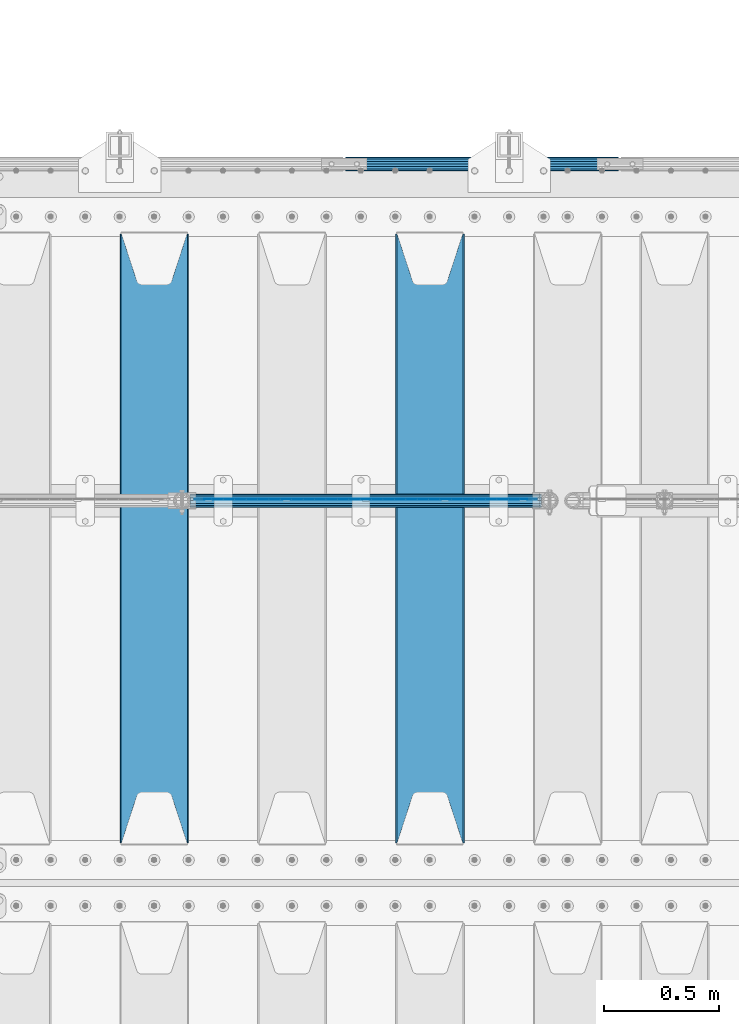
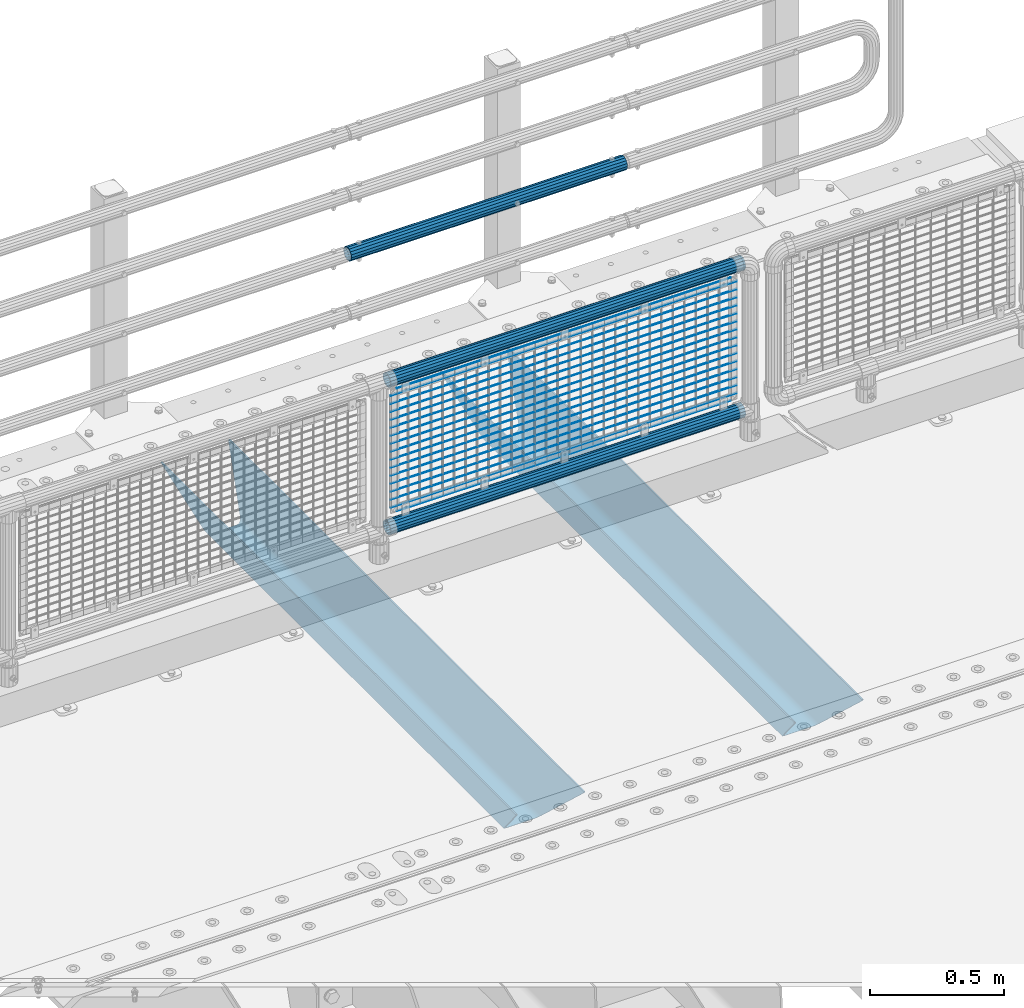
# One storey, part 129 of 247: 22 beams.
"""IFC2X3 building model written with IfcOpenShell, lengths in millimetres."""

from ifc_helpers import new_model, si_unit, frame, origin_with_axes, place, context, subcontext, project, spatial, faceted_brep, material, type_object, element, save


model = new_model("IFC2X3")

# Units and contexts
model_context = context("Model", 3, precision=1e-05, world=origin_with_axes())
body_context = subcontext(model_context, "Body", "Model", "MODEL_VIEW")
ifc_project = project(units=[si_unit("LENGTHUNIT", "METRE", prefix="MILLI"), si_unit("AREAUNIT", "SQUARE_METRE"), si_unit("VOLUMEUNIT", "CUBIC_METRE"), si_unit("MASSUNIT", "GRAM", prefix="KILO"), si_unit("TIMEUNIT", "SECOND"), si_unit("PLANEANGLEUNIT", "RADIAN"), si_unit("SOLIDANGLEUNIT", "STERADIAN"), si_unit("THERMODYNAMICTEMPERATUREUNIT", "DEGREE_CELSIUS"), si_unit("LUMINOUSINTENSITYUNIT", "LUMEN")], contexts=[model_context])

# Site, building, storey
site_placement = place(None, origin_with_axes())
site = spatial("IfcSite", under=ifc_project, at=site_placement, CompositionType="ELEMENT")
building_placement = place(site_placement, origin_with_axes())
building = spatial("IfcBuilding", under=site, at=building_placement, Name="Standard", CompositionType="ELEMENT")
storey_placement = place(building_placement, origin_with_axes())
storey = spatial("IfcBuildingStorey", under=building, at=storey_placement, Name="Undefined", CompositionType="ELEMENT", Elevation=0.0)

# Beams
ifc_material_1 = material(Name="STEEL/S355N")
beam_type_1 = type_object("IfcBeamType", PredefinedType="NOTDEFINED")
beam_1_placement = place(storey_placement, frame((14500.0, 6175.0, -115.0), z_axis=(0.0, 0.0, 1.0), x_axis=(0.0, 1.0, 0.0)))
element("IfcBeam", 1, at=beam_1_placement, inside=storey, type_object=beam_type_1, material=ifc_material_1, context=body_context, shape_type="Brep", body=[
    faceted_brep([(0.0, 150.0, 115.0), (0.0, 143.689999999999, 115.0), (2650.00000000297, 143.689999999999, 115.0), (2650.00000000297, 150.0, 115.0), (2650.00000000297, 142.059565218402, 110.0000000031), (2650.00000000297, 148.369565218403, 110.0000000031), (2441.90079219208, -80.1103600731112, -98.0992078077845), (2437.7588105432, -77.5672621345584, -102.241189456673), (2434.06523489746, -74.4080125315522, -105.934765102404), (2430.91086095089, -70.710272125576, -109.089139048974), (2428.37322971128, -66.5649389910068, -111.626770288588), (2426.51472138054, -62.0739139532889, -113.485278619323), (2425.38102192091, -57.3475956567672, -114.618978078955), (2424.99999999987, -52.5021667386536, -115.0), (2424.99999999987, 52.5021667386536, -115.0), (2425.38102192091, 57.3475956567672, -114.618978078955), (2426.51472138054, 62.0739139532889, -113.485278619323), (2428.37322971128, 66.5649389910068, -111.626770288588), (2430.91086095089, 70.710272125576, -109.089139048974), (2434.06523489746, 74.4080125315522, -105.934765102404), (2437.7588105432, 77.5672621345584, -102.241189456673), (2441.90079219208, 80.1103600731112, -98.0992078077846), (2446.38936140511, 81.9747917625791, -93.6106385947584), (2448.24948500409, 76.2713538057251, -91.7505149957729), (2444.62967112262, 74.76777986261, -95.3703288772456), (2441.28936334126, 72.7168944282894, -98.710636658607), (2438.31067330438, 70.1691124903846, -101.689326695487), (2435.76682334747, 67.1870637758839, -104.233176652398), (2433.72034654133, 63.8440531834895, -106.279653458539), (2432.22154950041, 60.222258798236, -107.778450499454), (2431.30727574265, 56.4107117849089, -108.692724257221), (2430.99999999987, 52.5031078186876, -109.0), (2430.99999999987, -52.5031078186876, -109.0), (2431.30727574265, -56.4107117849089, -108.692724257221), (2432.22154950041, -60.222258798236, -107.778450499454), (2433.72034654133, -63.8440531834895, -106.279653458539), (2435.76682334747, -67.1870637758839, -104.233176652398), (2438.31067330438, -70.1691124903846, -101.689326695487), (2441.28936334126, -72.7168944282894, -98.7106366586071), (2444.62967112262, -74.76777986261, -95.3703288772457), (2448.24948500409, -76.2713538057251, -91.7505149957729), (2650.00000000297, -142.059565218402, 110.0000000031), (2650.00000000297, -148.369565218403, 110.0000000031), (2446.38936140511, -81.9747917625791, -93.6106385947584), (2650.00000000297, -143.689999999999, 115.0), (2650.00000000297, -150.0, 115.0), (0.0, -143.689999999999, 115.0), (0.0, -150.0, 115.0), (0.0, -148.369565218261, 110.000000002663), (203.610638597422, -81.9747917625791, -93.6106385947584), (208.099207810448, -80.1103600731112, -98.0992078077845), (212.241189459336, -77.5672621345584, -102.241189456673), (215.934765105068, -74.4080125315522, -105.934765102404), (219.089139051637, -70.710272125576, -109.089139048974), (221.626770291251, -66.5649389910068, -111.626770288588), (223.485278621985, -62.0739139532889, -113.485278619323), (224.618978081617, -57.3475956567672, -114.618978078955), (225.000000002663, -52.5021667386536, -115.0), (225.000000002663, 52.5021667386536, -115.0), (224.618978081617, 57.3475956567672, -114.618978078955), (223.485278621985, 62.0739139532889, -113.485278619323), (221.626770291251, 66.5649389910068, -111.626770288588), (219.089139051637, 70.710272125576, -109.089139048974), (215.934765105068, 74.4080125315522, -105.934765102404), (212.241189459336, 77.5672621345584, -102.241189456673), (208.099207810448, 80.1103600731112, -98.0992078077846), (203.610638597422, 81.9747917625791, -93.6106385947584), (0.0, 148.369565218261, 110.000000002663), (0.0, 142.05956521826, 110.000000002663), (201.750514998436, 76.2713538057251, -91.7505149957729), (205.370328879908, 74.76777986261, -95.3703288772456), (208.710636661271, 72.7168944282894, -98.710636658607), (211.68932669815, 70.1691124903846, -101.689326695487), (214.233176655061, 67.1870637758839, -104.233176652398), (216.279653461202, 63.8440531834895, -106.279653458539), (217.778450502117, 60.222258798236, -107.778450499454), (218.692724259885, 56.4107117849089, -108.692724257221), (219.000000002663, 52.5031078186876, -109.0), (219.000000002663, -52.5031078186876, -109.0), (218.692724259885, -56.4107117849089, -108.692724257221), (217.778450502117, -60.222258798236, -107.778450499454), (216.279653461202, -63.8440531834895, -106.279653458539), (214.233176655061, -67.1870637758839, -104.233176652398), (211.68932669815, -70.1691124903846, -101.689326695487), (208.710636661271, -72.7168944282894, -98.7106366586071), (205.370328879908, -74.76777986261, -95.3703288772457), (201.750514998436, -76.2713538057251, -91.7505149957729), (0.0, -142.05956521826, 110.000000002663)], [[[0, 1, 2, 3]], [[3, 2, 4, 5]], [[6, 7, 8, 9, 10, 11, 12, 13, 14, 15, 16, 17, 18, 19, 20, 21, 22, 5, 4, 23, 24, 25, 26, 27, 28, 29, 30, 31, 32, 33, 34, 35, 36, 37, 38, 39, 40, 41, 42, 43]], [[44, 45, 42, 41]], [[46, 47, 45, 44]], [[43, 42, 45, 47, 48, 49]], [[6, 43, 49, 50]], [[7, 6, 50, 51]], [[8, 7, 51, 52]], [[9, 8, 52, 53]], [[10, 9, 53, 54]], [[11, 10, 54, 55]], [[12, 11, 55, 56]], [[13, 12, 56, 57]], [[14, 13, 57, 58]], [[15, 14, 58, 59]], [[16, 15, 59, 60]], [[17, 16, 60, 61]], [[18, 17, 61, 62]], [[19, 18, 62, 63]], [[20, 19, 63, 64]], [[21, 20, 64, 65]], [[22, 21, 65, 66]], [[0, 3, 5, 22, 66, 67]], [[1, 0, 67, 68]], [[23, 4, 2, 1, 68, 69]], [[24, 23, 69, 70]], [[25, 24, 70, 71]], [[26, 25, 71, 72]], [[27, 26, 72, 73]], [[28, 27, 73, 74]], [[29, 28, 74, 75]], [[30, 29, 75, 76]], [[31, 30, 76, 77]], [[32, 31, 77, 78]], [[33, 32, 78, 79]], [[34, 33, 79, 80]], [[35, 34, 80, 81]], [[36, 35, 81, 82]], [[37, 36, 82, 83]], [[38, 37, 83, 84]], [[39, 38, 84, 85]], [[40, 39, 85, 86]], [[46, 44, 41, 40, 86, 87]], [[47, 46, 87, 48]], [[86, 85, 84, 83, 82, 81, 80, 79, 78, 77, 76, 75, 74, 73, 72, 71, 70, 69, 68, 67, 66, 65, 64, 63, 62, 61, 60, 59, 58, 57, 56, 55, 54, 53, 52, 51, 50, 49, 48, 87]]]),
])
beam_2_placement = place(storey_placement, frame((13300.0, 6175.0, -115.0), z_axis=(0.0, 0.0, 1.0), x_axis=(0.0, 1.0, 0.0)))
element("IfcBeam", 2, at=beam_2_placement, inside=storey, type_object=beam_type_1, material=ifc_material_1, context=body_context, shape_type="Brep", body=[
    faceted_brep([(0.0, 150.0, 115.0), (0.0, 143.689999999999, 115.0), (2650.00000000297, 143.689999999999, 115.0), (2650.00000000297, 150.0, 115.0), (2650.00000000297, 142.059565218402, 110.0000000031), (2650.00000000297, 148.369565218403, 110.0000000031), (2441.90079219208, -80.1103600731112, -98.0992078077845), (2437.7588105432, -77.5672621345584, -102.241189456673), (2434.06523489746, -74.4080125315522, -105.934765102404), (2430.91086095089, -70.710272125576, -109.089139048974), (2428.37322971128, -66.5649389910068, -111.626770288588), (2426.51472138054, -62.0739139532889, -113.485278619323), (2425.38102192091, -57.3475956567672, -114.618978078955), (2424.99999999987, -52.5021667386536, -115.0), (2424.99999999987, 52.5021667386536, -115.0), (2425.38102192091, 57.3475956567672, -114.618978078955), (2426.51472138054, 62.0739139532889, -113.485278619323), (2428.37322971128, 66.5649389910068, -111.626770288588), (2430.91086095089, 70.710272125576, -109.089139048974), (2434.06523489746, 74.4080125315522, -105.934765102404), (2437.7588105432, 77.5672621345584, -102.241189456673), (2441.90079219208, 80.1103600731112, -98.0992078077846), (2446.38936140511, 81.9747917625791, -93.6106385947584), (2448.24948500409, 76.2713538057251, -91.7505149957729), (2444.62967112262, 74.76777986261, -95.3703288772456), (2441.28936334126, 72.7168944282894, -98.710636658607), (2438.31067330438, 70.1691124903846, -101.689326695487), (2435.76682334747, 67.1870637758839, -104.233176652398), (2433.72034654133, 63.8440531834895, -106.279653458539), (2432.22154950041, 60.222258798236, -107.778450499454), (2431.30727574265, 56.4107117849089, -108.692724257221), (2430.99999999987, 52.5031078186876, -109.0), (2430.99999999987, -52.5031078186876, -109.0), (2431.30727574265, -56.4107117849089, -108.692724257221), (2432.22154950041, -60.222258798236, -107.778450499454), (2433.72034654133, -63.8440531834895, -106.279653458539), (2435.76682334747, -67.1870637758839, -104.233176652398), (2438.31067330438, -70.1691124903846, -101.689326695487), (2441.28936334126, -72.7168944282894, -98.7106366586071), (2444.62967112262, -74.76777986261, -95.3703288772457), (2448.24948500409, -76.2713538057251, -91.7505149957729), (2650.00000000297, -142.059565218402, 110.0000000031), (2650.00000000297, -148.369565218403, 110.0000000031), (2446.38936140511, -81.9747917625791, -93.6106385947584), (2650.00000000297, -143.689999999999, 115.0), (2650.00000000297, -150.0, 115.0), (0.0, -143.689999999999, 115.0), (0.0, -150.0, 115.0), (0.0, -148.369565218261, 110.000000002663), (203.610638597422, -81.9747917625791, -93.6106385947584), (208.099207810448, -80.1103600731112, -98.0992078077845), (212.241189459336, -77.5672621345584, -102.241189456673), (215.934765105068, -74.4080125315522, -105.934765102404), (219.089139051637, -70.710272125576, -109.089139048974), (221.626770291251, -66.5649389910068, -111.626770288588), (223.485278621985, -62.0739139532889, -113.485278619323), (224.618978081617, -57.3475956567672, -114.618978078955), (225.000000002663, -52.5021667386536, -115.0), (225.000000002663, 52.5021667386536, -115.0), (224.618978081617, 57.3475956567672, -114.618978078955), (223.485278621985, 62.0739139532889, -113.485278619323), (221.626770291251, 66.5649389910068, -111.626770288588), (219.089139051637, 70.710272125576, -109.089139048974), (215.934765105068, 74.4080125315522, -105.934765102404), (212.241189459336, 77.5672621345584, -102.241189456673), (208.099207810448, 80.1103600731112, -98.0992078077846), (203.610638597422, 81.9747917625791, -93.6106385947584), (0.0, 148.369565218261, 110.000000002663), (0.0, 142.05956521826, 110.000000002663), (201.750514998436, 76.2713538057251, -91.7505149957729), (205.370328879908, 74.76777986261, -95.3703288772456), (208.710636661271, 72.7168944282894, -98.710636658607), (211.68932669815, 70.1691124903846, -101.689326695487), (214.233176655061, 67.1870637758839, -104.233176652398), (216.279653461202, 63.8440531834895, -106.279653458539), (217.778450502117, 60.222258798236, -107.778450499454), (218.692724259885, 56.4107117849089, -108.692724257221), (219.000000002663, 52.5031078186876, -109.0), (219.000000002663, -52.5031078186876, -109.0), (218.692724259885, -56.4107117849089, -108.692724257221), (217.778450502117, -60.222258798236, -107.778450499454), (216.279653461202, -63.8440531834895, -106.279653458539), (214.233176655061, -67.1870637758839, -104.233176652398), (211.68932669815, -70.1691124903846, -101.689326695487), (208.710636661271, -72.7168944282894, -98.7106366586071), (205.370328879908, -74.76777986261, -95.3703288772457), (201.750514998436, -76.2713538057251, -91.7505149957729), (0.0, -142.05956521826, 110.000000002663)], [[[0, 1, 2, 3]], [[3, 2, 4, 5]], [[6, 7, 8, 9, 10, 11, 12, 13, 14, 15, 16, 17, 18, 19, 20, 21, 22, 5, 4, 23, 24, 25, 26, 27, 28, 29, 30, 31, 32, 33, 34, 35, 36, 37, 38, 39, 40, 41, 42, 43]], [[44, 45, 42, 41]], [[46, 47, 45, 44]], [[43, 42, 45, 47, 48, 49]], [[6, 43, 49, 50]], [[7, 6, 50, 51]], [[8, 7, 51, 52]], [[9, 8, 52, 53]], [[10, 9, 53, 54]], [[11, 10, 54, 55]], [[12, 11, 55, 56]], [[13, 12, 56, 57]], [[14, 13, 57, 58]], [[15, 14, 58, 59]], [[16, 15, 59, 60]], [[17, 16, 60, 61]], [[18, 17, 61, 62]], [[19, 18, 62, 63]], [[20, 19, 63, 64]], [[21, 20, 64, 65]], [[22, 21, 65, 66]], [[0, 3, 5, 22, 66, 67]], [[1, 0, 67, 68]], [[23, 4, 2, 1, 68, 69]], [[24, 23, 69, 70]], [[25, 24, 70, 71]], [[26, 25, 71, 72]], [[27, 26, 72, 73]], [[28, 27, 73, 74]], [[29, 28, 74, 75]], [[30, 29, 75, 76]], [[31, 30, 76, 77]], [[32, 31, 77, 78]], [[33, 32, 78, 79]], [[34, 33, 79, 80]], [[35, 34, 80, 81]], [[36, 35, 81, 82]], [[37, 36, 82, 83]], [[38, 37, 83, 84]], [[39, 38, 84, 85]], [[40, 39, 85, 86]], [[46, 44, 41, 40, 86, 87]], [[47, 46, 87, 48]], [[86, 85, 84, 83, 82, 81, 80, 79, 78, 77, 76, 75, 74, 73, 72, 71, 70, 69, 68, 67, 66, 65, 64, 63, 62, 61, 60, 59, 58, 57, 56, 55, 54, 53, 52, 51, 50, 49, 48, 87]]]),
])
ifc_material_2 = material()
beam_type_2 = type_object("IfcBeamType", PredefinedType="NOTDEFINED")
beam_3_placement = place(storey_placement, frame((14132.0000000001, 9129.8499999996, 419.849999999725), z_axis=(0.0, -0.999999999999548, -9.5100000000016e-07), x_axis=(1.0, 0.0, 0.0)))
element("IfcBeam", 3, at=beam_3_placement, inside=storey, type_object=beam_type_2, material=ifc_material_2, context=body_context, shape_type="Brep", body=[
    faceted_brep([(0.0, -26.5499999999993, 0.0), (0.0, -24.5290015881747, 10.1602451292931), (1190.0, -24.5290015881747, 10.1602451292929), (1190.0, -26.55, 0.0), (0.0, -18.7736850405036, 18.7736850405028), (1190.0, -18.7736850405028, 18.7736850405036), (0.0, -10.1602451292929, 24.5290015881747), (1190.0, -10.1602451292931, 24.5290015881747), (0.0, 0.0, 26.55), (1190.0, 0.0, 26.5499999999993), (0.0, 10.1602451292929, 24.5290015881747), (1190.0, 10.1602451292932, 24.5290015881747), (0.0, 18.7736850405036, 18.7736850405028), (1190.0, 18.7736850405029, 18.7736850405036), (0.0, 24.5290015881747, 10.1602451292931), (1190.0, 24.5290015881747, 10.1602451292929), (0.0, 26.5499999999993, 0.0), (1190.0, 26.55, 0.0), (0.0, 24.5290015881747, -10.1602451292931), (1190.0, 24.5290015881747, -10.1602451292929), (0.0, 18.7736850405036, -18.7736850405028), (1190.0, 18.7736850405028, -18.7736850405036), (0.0, 10.1602451292929, -24.5290015881747), (1190.0, 10.1602451292931, -24.5290015881747), (0.0, 0.0, -26.55), (1190.0, 0.0, -26.5499999999993), (0.0, -10.1602451292929, -24.5290015881747), (1190.0, -10.1602451292931, -24.5290015881747), (0.0, -18.7736850405036, -18.7736850405028), (1190.0, -18.7736850405028, -18.7736850405036), (0.0, -24.5290015881747, -10.1602451292931), (1190.0, -24.5290015881747, -10.1602451292929), (0.0, -30.1499999999996, 0.0), (0.0, -27.8549679052148, -11.5379054858076), (1190.0, -27.8549679052153, -11.5379054858076), (1190.0, -30.15, 0.0), (0.0, -21.3192694527743, -21.3192694527752), (1190.0, -21.3192694527744, -21.3192694527752), (0.0, -11.5379054858076, -27.8549679052157), (1190.0, -11.5379054858075, -27.8549679052157), (0.0, 0.0, -30.1499999999996), (1190.0, 0.0, -30.1499999999996), (0.0, 11.5379054858076, -27.8549679052157), (1190.0, 11.5379054858075, -27.8549679052157), (0.0, 21.3192694527743, -21.3192694527752), (1190.0, 21.3192694527744, -21.3192694527752), (0.0, 27.8549679052157, -11.5379054858076), (1190.0, 27.8549679052153, -11.5379054858076), (0.0, 30.1499999999996, 0.0), (1190.0, 30.15, 0.0), (0.0, 27.8549679052157, 11.5379054858076), (1190.0, 27.8549679052153, 11.5379054858076), (0.0, 21.3192694527743, 21.3192694527752), (1190.0, 21.3192694527744, 21.3192694527752), (0.0, 11.5379054858076, 27.8549679052157), (1190.0, 11.5379054858075, 27.8549679052157), (0.0, 0.0, 30.1499999999996), (1190.0, 0.0, 30.1499999999996), (0.0, -11.5379054858076, 27.8549679052157), (1190.0, -11.5379054858075, 27.8549679052157), (0.0, -21.3192694527743, 21.3192694527752), (1190.0, -21.3192694527744, 21.3192694527752), (0.0, -27.8549679052157, 11.5379054858076), (1190.0, -27.8549679052153, 11.5379054858076)], [[[0, 1, 2, 3]], [[1, 4, 5, 2]], [[4, 6, 7, 5]], [[6, 8, 9, 7]], [[8, 10, 11, 9]], [[10, 12, 13, 11]], [[12, 14, 15, 13]], [[14, 16, 17, 15]], [[16, 18, 19, 17]], [[18, 20, 21, 19]], [[20, 22, 23, 21]], [[22, 24, 25, 23]], [[24, 26, 27, 25]], [[26, 28, 29, 27]], [[28, 30, 31, 29]], [[30, 0, 3, 31]], [[32, 33, 34, 35]], [[33, 36, 37, 34]], [[36, 38, 39, 37]], [[38, 40, 41, 39]], [[40, 42, 43, 41]], [[42, 44, 45, 43]], [[44, 46, 47, 45]], [[46, 48, 49, 47]], [[48, 50, 51, 49]], [[50, 52, 53, 51]], [[52, 54, 55, 53]], [[54, 56, 57, 55]], [[56, 58, 59, 57]], [[58, 60, 61, 59]], [[60, 62, 63, 61]], [[62, 32, 35, 63]], [[37, 39, 41, 43, 45, 47, 49, 51, 53, 55, 57, 59, 61, 63, 35, 34], [5, 7, 9, 11, 13, 15, 17, 19, 21, 23, 25, 27, 29, 31, 3, 2]], [[62, 60, 58, 56, 54, 52, 50, 48, 46, 44, 42, 40, 38, 36, 33, 32], [30, 28, 26, 24, 22, 20, 18, 16, 14, 12, 10, 8, 6, 4, 1, 0]]]),
])
beam_type_3 = type_object("IfcBeamType", PredefinedType="NOTDEFINED")
beam_4_placement = place(storey_placement, frame((13455.85, 7664.50000000001, 298.170000000007), z_axis=(0.0, 0.0, 1.0), x_axis=(1.0, 0.0, 0.0)))
element("IfcBeam", 4, at=beam_4_placement, inside=storey, type_object=beam_type_3, material=ifc_material_2, context=body_context, shape_type="Brep", body=[
    faceted_brep([(0.0, -25.3500000000004, 0.0), (0.0, -23.4203461491616, 9.70102501045585), (1530.0, -23.4203461491616, 9.70102501045506), (1530.0, -25.3500000000004, 0.0), (0.0, -17.9251569030794, 17.9251569030785), (1530.0, -17.9251569030794, 17.925156903079), (0.0, -9.70102501045494, 23.4203461491616), (1530.0, -9.70102501045494, 23.4203461491611), (0.0, 0.0, 25.3500000000004), (1530.0, 0.0, 25.35), (0.0, 9.70102501045494, 23.4203461491616), (1530.0, 9.70102501045494, 23.4203461491611), (0.0, 17.9251569030794, 17.9251569030785), (1530.0, 17.9251569030794, 17.925156903079), (0.0, 23.4203461491616, 9.70102501045585), (1530.0, 23.4203461491616, 9.70102501045506), (0.0, 25.3500000000004, 0.0), (1530.0, 25.3500000000004, 0.0), (0.0, 23.4203461491616, -9.70102501045585), (1530.0, 23.4203461491616, -9.70102501045506), (0.0, 17.9251569030794, -17.9251569030785), (1530.0, 17.9251569030794, -17.925156903079), (0.0, 9.70102501045494, -23.4203461491616), (1530.0, 9.70102501045494, -23.4203461491611), (0.0, 0.0, -25.3500000000004), (1530.0, 0.0, -25.35), (0.0, -9.70102501045494, -23.4203461491616), (1530.0, -9.70102501045494, -23.4203461491611), (0.0, -17.9251569030794, -17.9251569030785), (1530.0, -17.9251569030794, -17.925156903079), (0.0, -23.4203461491616, -9.70102501045585), (1530.0, -23.4203461491616, -9.70102501045506), (0.0, -30.1499999999996, 0.0), (0.0, -27.8549679052148, -11.5379054858076), (1530.0, -27.8549679052148, -11.5379054858075), (1530.0, -30.1499999999996, 0.0), (0.0, -21.3192694527743, -21.3192694527752), (1530.0, -21.3192694527743, -21.3192694527744), (0.0, -11.5379054858076, -27.8549679052157), (1530.0, -11.5379054858076, -27.8549679052153), (0.0, 0.0, -30.1499999999996), (1530.0, 0.0, -30.15), (0.0, 11.5379054858076, -27.8549679052157), (1530.0, 11.5379054858076, -27.8549679052153), (0.0, 21.3192694527743, -21.3192694527752), (1530.0, 21.3192694527743, -21.3192694527744), (0.0, 27.8549679052157, -11.5379054858076), (1530.0, 27.8549679052157, -11.5379054858074), (0.0, 30.1499999999996, 0.0), (1530.0, 30.1499999999996, 0.0), (0.0, 27.8549679052157, 11.5379054858076), (1530.0, 27.8549679052157, 11.5379054858074), (0.0, 21.3192694527743, 21.3192694527752), (1530.0, 21.3192694527743, 21.3192694527744), (0.0, 11.5379054858076, 27.8549679052157), (1530.0, 11.5379054858076, 27.8549679052153), (0.0, 0.0, 30.1499999999996), (1530.0, 0.0, 30.15), (0.0, -11.5379054858076, 27.8549679052157), (1530.0, -11.5379054858076, 27.8549679052153), (0.0, -21.3192694527743, 21.3192694527752), (1530.0, -21.3192694527743, 21.3192694527744), (0.0, -27.8549679052157, 11.5379054858076), (1530.0, -27.8549679052157, 11.5379054858074)], [[[0, 1, 2, 3]], [[1, 4, 5, 2]], [[4, 6, 7, 5]], [[6, 8, 9, 7]], [[8, 10, 11, 9]], [[10, 12, 13, 11]], [[12, 14, 15, 13]], [[14, 16, 17, 15]], [[16, 18, 19, 17]], [[18, 20, 21, 19]], [[20, 22, 23, 21]], [[22, 24, 25, 23]], [[24, 26, 27, 25]], [[26, 28, 29, 27]], [[28, 30, 31, 29]], [[30, 0, 3, 31]], [[32, 33, 34, 35]], [[33, 36, 37, 34]], [[36, 38, 39, 37]], [[38, 40, 41, 39]], [[40, 42, 43, 41]], [[42, 44, 45, 43]], [[44, 46, 47, 45]], [[46, 48, 49, 47]], [[48, 50, 51, 49]], [[50, 52, 53, 51]], [[52, 54, 55, 53]], [[54, 56, 57, 55]], [[56, 58, 59, 57]], [[58, 60, 61, 59]], [[60, 62, 63, 61]], [[62, 32, 35, 63]], [[37, 39, 41, 43, 45, 47, 49, 51, 53, 55, 57, 59, 61, 63, 35, 34], [5, 7, 9, 11, 13, 15, 17, 19, 21, 23, 25, 27, 29, 31, 3, 2]], [[62, 60, 58, 56, 54, 52, 50, 48, 46, 44, 42, 40, 38, 36, 33, 32], [30, 28, 26, 24, 22, 20, 18, 16, 14, 12, 10, 8, 6, 4, 1, 0]]]),
])
beam_5_placement = place(storey_placement, frame((13455.85, 7664.50000000001, 969.850000000006), z_axis=(0.0, 0.0, 1.0), x_axis=(1.0, 0.0, 0.0)))
element("IfcBeam", 5, at=beam_5_placement, inside=storey, type_object=beam_type_3, material=ifc_material_2, context=body_context, shape_type="Brep", body=[
    faceted_brep([(0.0, -25.3500000000004, 0.0), (0.0, -23.4203461491616, 9.70102501045585), (1530.0, -23.4203461491616, 9.70102501045506), (1530.0, -25.3500000000004, 0.0), (0.0, -17.9251569030794, 17.9251569030785), (1530.0, -17.9251569030794, 17.925156903079), (0.0, -9.70102501045494, 23.4203461491616), (1530.0, -9.70102501045494, 23.4203461491611), (0.0, 0.0, 25.3500000000004), (1530.0, 0.0, 25.35), (0.0, 9.70102501045494, 23.4203461491616), (1530.0, 9.70102501045494, 23.4203461491611), (0.0, 17.9251569030794, 17.9251569030785), (1530.0, 17.9251569030794, 17.925156903079), (0.0, 23.4203461491616, 9.70102501045585), (1530.0, 23.4203461491616, 9.70102501045506), (0.0, 25.3500000000004, 0.0), (1530.0, 25.3500000000004, 0.0), (0.0, 23.4203461491616, -9.70102501045585), (1530.0, 23.4203461491616, -9.70102501045506), (0.0, 17.9251569030794, -17.9251569030785), (1530.0, 17.9251569030794, -17.925156903079), (0.0, 9.70102501045494, -23.4203461491616), (1530.0, 9.70102501045494, -23.4203461491611), (0.0, 0.0, -25.3500000000004), (1530.0, 0.0, -25.35), (0.0, -9.70102501045494, -23.4203461491616), (1530.0, -9.70102501045494, -23.4203461491611), (0.0, -17.9251569030794, -17.9251569030785), (1530.0, -17.9251569030794, -17.925156903079), (0.0, -23.4203461491616, -9.70102501045585), (1530.0, -23.4203461491616, -9.70102501045506), (0.0, -30.1499999999996, 0.0), (0.0, -27.8549679052148, -11.5379054858076), (1530.0, -27.8549679052148, -11.5379054858075), (1530.0, -30.1499999999996, 0.0), (0.0, -21.3192694527743, -21.3192694527752), (1530.0, -21.3192694527743, -21.3192694527744), (0.0, -11.5379054858076, -27.8549679052157), (1530.0, -11.5379054858076, -27.8549679052153), (0.0, 0.0, -30.1499999999996), (1530.0, 0.0, -30.15), (0.0, 11.5379054858076, -27.8549679052157), (1530.0, 11.5379054858076, -27.8549679052153), (0.0, 21.3192694527743, -21.3192694527752), (1530.0, 21.3192694527743, -21.3192694527744), (0.0, 27.8549679052157, -11.5379054858076), (1530.0, 27.8549679052157, -11.5379054858074), (0.0, 30.1499999999996, 0.0), (1530.0, 30.1499999999996, 0.0), (0.0, 27.8549679052157, 11.5379054858076), (1530.0, 27.8549679052157, 11.5379054858074), (0.0, 21.3192694527743, 21.3192694527752), (1530.0, 21.3192694527743, 21.3192694527744), (0.0, 11.5379054858076, 27.8549679052157), (1530.0, 11.5379054858076, 27.8549679052153), (0.0, 0.0, 30.1499999999996), (1530.0, 0.0, 30.15), (0.0, -11.5379054858076, 27.8549679052157), (1530.0, -11.5379054858076, 27.8549679052153), (0.0, -21.3192694527743, 21.3192694527752), (1530.0, -21.3192694527743, 21.3192694527744), (0.0, -27.8549679052157, 11.5379054858076), (1530.0, -27.8549679052157, 11.5379054858074)], [[[0, 1, 2, 3]], [[1, 4, 5, 2]], [[4, 6, 7, 5]], [[6, 8, 9, 7]], [[8, 10, 11, 9]], [[10, 12, 13, 11]], [[12, 14, 15, 13]], [[14, 16, 17, 15]], [[16, 18, 19, 17]], [[18, 20, 21, 19]], [[20, 22, 23, 21]], [[22, 24, 25, 23]], [[24, 26, 27, 25]], [[26, 28, 29, 27]], [[28, 30, 31, 29]], [[30, 0, 3, 31]], [[32, 33, 34, 35]], [[33, 36, 37, 34]], [[36, 38, 39, 37]], [[38, 40, 41, 39]], [[40, 42, 43, 41]], [[42, 44, 45, 43]], [[44, 46, 47, 45]], [[46, 48, 49, 47]], [[48, 50, 51, 49]], [[50, 52, 53, 51]], [[52, 54, 55, 53]], [[54, 56, 57, 55]], [[56, 58, 59, 57]], [[58, 60, 61, 59]], [[60, 62, 63, 61]], [[62, 32, 35, 63]], [[37, 39, 41, 43, 45, 47, 49, 51, 53, 55, 57, 59, 61, 63, 35, 34], [5, 7, 9, 11, 13, 15, 17, 19, 21, 23, 25, 27, 29, 31, 3, 2]], [[62, 60, 58, 56, 54, 52, 50, 48, 46, 44, 42, 40, 38, 36, 33, 32], [30, 28, 26, 24, 22, 20, 18, 16, 14, 12, 10, 8, 6, 4, 1, 0]]]),
])
ifc_material_3 = material(Name="Misc_Undefined")
beam_type_4 = type_object("IfcBeamType", Name="D3", PredefinedType="NOTDEFINED")
for number, where, z_axis, x_axis in (
    (6, (13476.0, 7670.50000000001, 851.597000000006), (0.0, 0.0, 1.0), (1.0, 0.0, 0.0)),
    (7, (13476.0, 7670.50000000001, 669.452000000006), (0.0, 0.0, 1.0), (1.0, 0.0, 0.0)),
    (8, (13476.0, 7670.50000000001, 523.736000000006), (0.0, 0.0, 1.0), (1.0, 0.0, 0.0)),
    (9, (13476.0, 7670.50000000001, 487.307000000006), (0.0, 0.0, 1.0), (1.0, 0.0, 0.0)),
    (10, (13476.0, 7670.50000000001, 705.881000000006), (0.0, 0.0, 1.0), (1.0, 0.0, 0.0)),
    (11, (13476.0, 7670.50000000001, 596.594000000006), (0.0, 0.0, 1.0), (1.0, 0.0, 0.0)),
    (12, (13476.0, 7670.50000000001, 450.878000000006), (0.0, 0.0, 1.0), (1.0, 0.0, 0.0)),
    (13, (13476.0, 7670.50000000001, 815.168000000006), (0.0, 0.0, 1.0), (1.0, 0.0, 0.0)),
    (14, (13476.0, 7670.50000000001, 888.026000000006), (0.0, 0.0, 1.0), (1.0, 0.0, 0.0)),
    (15, (13476.0, 7670.50000000001, 778.739000000006), (0.0, 0.0, 1.0), (1.0, 0.0, 0.0)),
    (16, (13476.0, 7670.50000000001, 742.310000000006), (0.0, 0.0, 1.0), (1.0, 0.0, 0.0)),
    (17, (13476.0, 7670.50000000001, 633.023000000006), (0.0, 0.0, 1.0), (1.0, 0.0, 0.0)),
    (18, (13476.0, 7670.50000000001, 560.165000000006), (0.0, 0.0, 1.0), (1.0, 0.0, 0.0)),
    (19, (13476.0, 7670.50000000001, 414.449000000006), (0.0, 0.0, 1.0), (1.0, 0.0, 0.0)),
):
    element("IfcBeam", number, at=place(storey_placement, frame(where, z_axis=z_axis, x_axis=x_axis)), inside=storey, type_object=beam_type_4, material=ifc_material_3, ObjectType="D3", context=body_context, shape_type="Brep", body=[
        faceted_brep([(1.81898940354586e-12, -1.5, -5.6843418860808e-14), (0.0, -0.75, -1.29903810567703), (1490.0, -0.75, -1.29903810567669), (1490.0, -1.5, 0.0), (0.0, 0.75, -1.29903810567703), (1490.0, 0.75, -1.29903810567669), (1.81898940354586e-12, 1.5, -5.6843418860808e-14), (1490.0, 1.5, 0.0), (0.0, 0.75, 1.29903810567703), (1490.0, 0.75, 1.29903810567669), (0.0, -0.75, 1.29903810567703), (1490.0, -0.75, 1.29903810567669)], [[[0, 1, 2, 3]], [[1, 4, 5, 2]], [[4, 6, 7, 5]], [[6, 8, 9, 7]], [[8, 10, 11, 9]], [[10, 0, 3, 11]], [[5, 7, 9, 11, 3, 2]], [[10, 8, 6, 4, 1, 0]]]),
    ])
beam_6_placement = place(storey_placement, frame((13501.0, 7670.50000000001, 353.020000000006), z_axis=(0.0, 0.0, 1.0), x_axis=(1.0, 0.0, 0.0)))
element("IfcBeam", 20, at=beam_6_placement, inside=storey, type_object=beam_type_4, material=ifc_material_3, ObjectType="D3", context=body_context, shape_type="Brep", body=[
    faceted_brep([(1.81898940354586e-12, -1.5, -5.6843418860808e-14), (0.0, -0.75, -1.29903810567703), (1440.0, -0.75, -1.29903810567669), (1440.0, -1.5, 0.0), (0.0, 0.75, -1.29903810567703), (1440.0, 0.75, -1.29903810567663), (1.81898940354586e-12, 1.5, -5.6843418860808e-14), (1440.0, 1.5, 0.0), (0.0, 0.75, 1.29903810567703), (1440.0, 0.75, 1.29903810567669), (0.0, -0.75, 1.29903810567703), (1440.0, -0.75, 1.29903810567669)], [[[0, 1, 2, 3]], [[1, 4, 5, 2]], [[4, 6, 7, 5]], [[6, 8, 9, 7]], [[8, 10, 11, 9]], [[10, 0, 3, 11]], [[5, 7, 9, 11, 3, 2]], [[10, 8, 6, 4, 1, 0]]]),
])
beam_7_placement = place(storey_placement, frame((13476.0, 7670.50000000001, 378.020000000006), z_axis=(0.0, 0.0, 1.0), x_axis=(1.0, 0.0, 0.0)))
element("IfcBeam", 21, at=beam_7_placement, inside=storey, type_object=beam_type_4, material=ifc_material_3, ObjectType="D3", context=body_context, shape_type="Brep", body=[
    faceted_brep([(1.81898940354586e-12, -1.5, -5.6843418860808e-14), (0.0, -0.75, -1.29903810567703), (1490.0, -0.75, -1.29903810567669), (1490.0, -1.5, 0.0), (0.0, 0.75, -1.29903810567703), (1490.0, 0.75, -1.29903810567669), (1.81898940354586e-12, 1.5, -5.6843418860808e-14), (1490.0, 1.5, 0.0), (0.0, 0.75, 1.29903810567703), (1490.0, 0.75, 1.29903810567669), (0.0, -0.75, 1.29903810567703), (1490.0, -0.75, 1.29903810567669)], [[[0, 1, 2, 3]], [[1, 4, 5, 2]], [[4, 6, 7, 5]], [[6, 8, 9, 7]], [[8, 10, 11, 9]], [[10, 0, 3, 11]], [[5, 7, 9, 11, 3, 2]], [[10, 8, 6, 4, 1, 0]]]),
])
beam_8_placement = place(storey_placement, frame((13501.0, 7670.50000000001, 913.020000000006), z_axis=(0.0, 0.0, 1.0), x_axis=(1.0, 0.0, 0.0)))
element("IfcBeam", 22, at=beam_8_placement, inside=storey, type_object=beam_type_4, material=ifc_material_3, ObjectType="D3", context=body_context, shape_type="Brep", body=[
    faceted_brep([(1.81898940354586e-12, -1.5, -5.6843418860808e-14), (0.0, -0.75, -1.29903810567703), (1440.0, -0.75, -1.29903810567669), (1440.0, -1.5, 0.0), (0.0, 0.75, -1.29903810567703), (1440.0, 0.75, -1.29903810567663), (1.81898940354586e-12, 1.5, -5.6843418860808e-14), (1440.0, 1.5, 0.0), (0.0, 0.75, 1.29903810567703), (1440.0, 0.75, 1.29903810567669), (0.0, -0.75, 1.29903810567703), (1440.0, -0.75, 1.29903810567669)], [[[0, 1, 2, 3]], [[1, 4, 5, 2]], [[4, 6, 7, 5]], [[6, 8, 9, 7]], [[8, 10, 11, 9]], [[10, 0, 3, 11]], [[5, 7, 9, 11, 3, 2]], [[10, 8, 6, 4, 1, 0]]]),
])

save(model, "model.ifc")
